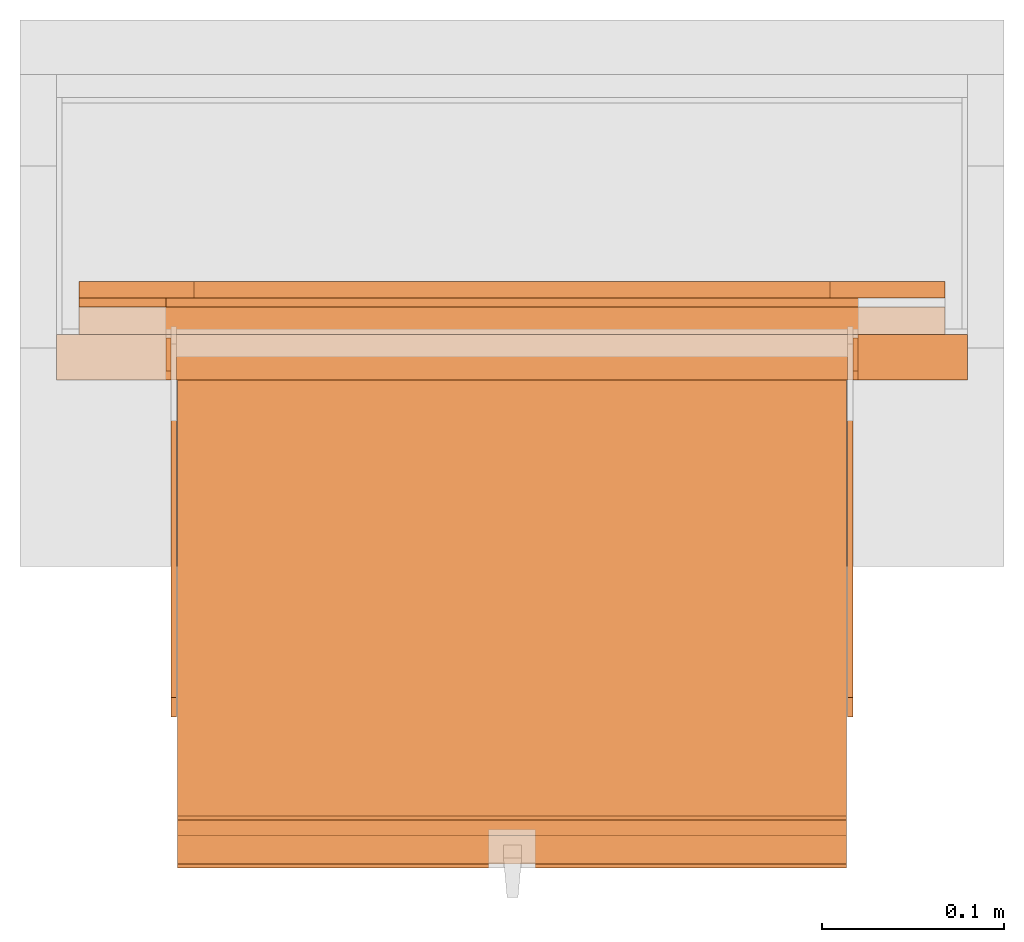
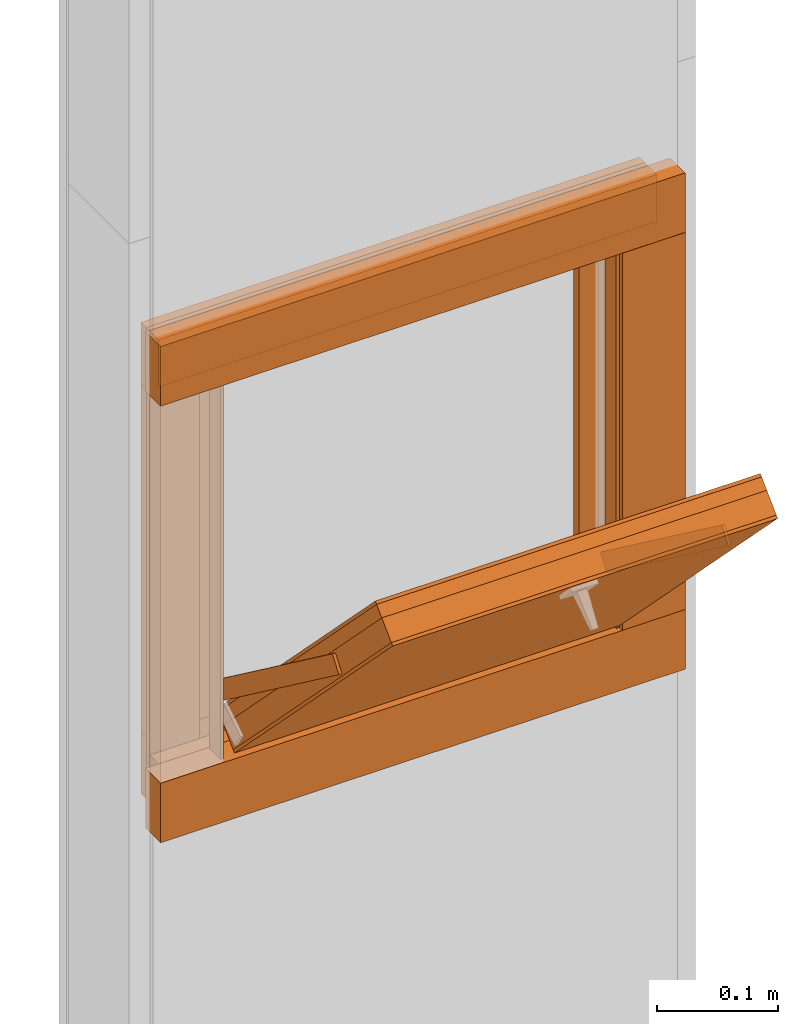
# One storey, part 2 of 4: 19 proxies.
"""IFC2X3 building model written with IfcOpenShell, lengths in metres."""

from ifc_helpers import new_model, entity, si_unit, converted_unit, derived_unit, money_unit, direction, frame, origin_with_axes, place, context, subcontext, project, spatial, polyline, outline, extrude, faceted_brep, source, transform, mapped, material, type_object, element, save


model = new_model("IFC2X3")

# Units and contexts
model_context = context("Model", 3, precision=1e-05, world=origin_with_axes(), true_north=direction((0.0, 1.0)))
plan_context = context("Plan", 3, precision=1e-05, world=origin_with_axes(), true_north=direction((0.0, 1.0)))
body_context = subcontext(model_context, "Body", "Model", "MODEL_VIEW")
ifc_project = project(units=[si_unit("LENGTHUNIT", "METRE"), si_unit("AREAUNIT", "SQUARE_METRE"), si_unit("VOLUMEUNIT", "CUBIC_METRE"), converted_unit("PLANEANGLEUNIT", "DEGREE", entity("IfcPlaneAngleMeasure", 0.0174532925199), si_unit("PLANEANGLEUNIT", "RADIAN"), dimensions=[0, 0, 0, 0, 0, 0, 0]), si_unit("SOLIDANGLEUNIT", "STERADIAN"), money_unit("CHF"), converted_unit("TIMEUNIT", "Year", entity("IfcTimeMeasure", 31556926.0), si_unit("TIMEUNIT", "SECOND"), dimensions=[0, 0, 1, 0, 0, 0, 0]), si_unit("MASSUNIT", "GRAM", prefix="KILO"), si_unit("THERMODYNAMICTEMPERATUREUNIT", "DEGREE_CELSIUS"), si_unit("LUMINOUSINTENSITYUNIT", "LUMEN"), si_unit("ENERGYUNIT", "JOULE", prefix="MEGA"), derived_unit("THERMALCONDUCTANCEUNIT", [(si_unit("POWERUNIT", "WATT"), 1), (si_unit("LENGTHUNIT", "METRE"), -1), (si_unit("THERMODYNAMICTEMPERATUREUNIT", "KELVIN"), -1)]), derived_unit("SPECIFICHEATCAPACITYUNIT", [(si_unit("ENERGYUNIT", "JOULE"), 1), (si_unit("MASSUNIT", "GRAM", prefix="KILO"), -1), (si_unit("THERMODYNAMICTEMPERATUREUNIT", "KELVIN"), -1)]), derived_unit("MASSDENSITYUNIT", [(si_unit("MASSUNIT", "GRAM", prefix="KILO"), 1), (si_unit("VOLUMEUNIT", "CUBIC_METRE"), -1)])], contexts=[model_context, plan_context])

# Site, building, storey
site_placement = place(None, origin_with_axes())
site = spatial("IfcSite", under=ifc_project, at=site_placement, CompositionType="ELEMENT")
building_placement = place(site_placement, origin_with_axes())
building = spatial("IfcBuilding", under=site, at=building_placement, CompositionType="ELEMENT")
storey_placement = place(building_placement, origin_with_axes())
storey = spatial("IfcBuildingStorey", under=building, at=storey_placement, Name="EG00", CompositionType="ELEMENT", Elevation=0.0)

# Proxies
ifc_material_1 = material(Name="Holz")
building_element_proxy_type_1 = type_object("IfcBuildingElementProxyType", Name="Holz 15", PredefinedType="NOTDEFINED")
for number, where, z_axis, x_axis, name in (
    (1, (9.60272436818, -8.21243070606, 0.5625), (0.0, 0.0, 1.0), (-1.0, 0.0, 0.0), "Wand-004"),
    (2, (9.60272436818, -8.21243070606, 0.99), (0.0, 0.0, 1.0), (-1.0, 0.0, 0.0), "Wand-004"),
):
    element("IfcBuildingElementProxy", number, at=place(storey_placement, frame(where, z_axis=z_axis, x_axis=x_axis)), inside=storey, type_object=building_element_proxy_type_1, material=ifc_material_1, Name=name, context=body_context, shape_type="SweptSolid", body=[
        extrude(outline(polyline([(0.0, 0.0), (0.475, 0.0), (0.475, 0.015), (0.0, 0.015), (0.0, 0.0)])), origin_with_axes(), (0.0, 0.0, 1.0), 0.0475),
    ])
building_element_proxy_type_2 = type_object("IfcBuildingElementProxyType", Name="Holz 5", PredefinedType="NOTDEFINED")
proxy_1_placement = place(storey_placement, frame((9.60272436818, -8.21243070606, 1.0), z_axis=(0.0, 0.0, 1.0), x_axis=(-1.0, 0.0, 0.0)))
element("IfcBuildingElementProxy", 3, at=proxy_1_placement, inside=storey, type_object=building_element_proxy_type_2, material=ifc_material_1, Name="Wand-004", context=body_context, shape_type="SweptSolid", body=[
    extrude(outline(polyline([(0.0, -0.005), (0.475, -0.005), (0.475, 0.0), (0.0, 0.0), (0.0, -0.005)])), origin_with_axes(), (0.0, 0.0, 1.0), 0.0375),
])
proxy_2_placement = place(storey_placement, frame((9.12772436818, -8.21243070606, 0.6), z_axis=(0.0, 0.0, 1.0), x_axis=(1.0, 0.0, 0.0)))
element("IfcBuildingElementProxy", 4, at=proxy_2_placement, inside=storey, type_object=building_element_proxy_type_2, material=ifc_material_1, Name="Wand-004", context=body_context, shape_type="SweptSolid", body=[
    extrude(outline(polyline([(0.0, 0.0), (0.0475, 0.0), (0.0475, 0.005), (0.0, 0.005), (0.0, 0.0)])), origin_with_axes(), (0.0, 0.0, 1.0), 0.4),
])
building_element_proxy_type_3 = type_object("IfcBuildingElementProxyType", Name="Holz 25", PredefinedType="NOTDEFINED")
for number, where, z_axis, x_axis, name in (
    (5, (9.61522436818, -8.22743070606, 0.55), (0.0, 0.0, 1.0), (-1.0, 0.0, 0.0), "Wand-004"),
    (6, (9.61522436818, -8.22743070606, 0.99), (0.0, 0.0, 1.0), (-1.0, 0.0, 0.0), "Wand-004"),
):
    element("IfcBuildingElementProxy", number, at=place(storey_placement, frame(where, z_axis=z_axis, x_axis=x_axis)), inside=storey, type_object=building_element_proxy_type_3, material=ifc_material_1, Name=name, context=body_context, shape_type="SweptSolid", body=[
        extrude(outline(polyline([(0.0, 0.0), (0.5, 0.0), (0.5, 0.025), (0.0, 0.025), (0.0, 0.0)])), origin_with_axes(), (0.0, 0.0, 1.0), 0.06),
    ])
proxy_3_placement = place(storey_placement, frame((9.55522436818, -8.25243070606, 0.61), z_axis=(0.0, 0.0, 1.0), x_axis=(1.0, 0.0, 0.0)))
element("IfcBuildingElementProxy", 7, at=proxy_3_placement, inside=storey, type_object=building_element_proxy_type_3, material=ifc_material_1, Name="Wand-004", context=body_context, shape_type="SweptSolid", body=[
    extrude(outline(polyline([(0.0, 0.0), (0.06, 0.0), (0.06, 0.025), (0.0, 0.025), (0.0, 0.0)])), origin_with_axes(), (0.0, 0.0, 1.0), 0.38),
])
ifc_material_2 = material(Name="Metall, Aluminium")
building_element_proxy_type_4 = type_object("IfcBuildingElementProxyType", Name="Metall, Aluminium 3", PredefinedType="NOTDEFINED")
proxy_4_placement = place(storey_placement, frame((9.17522436818, -8.22943070606, 0.61), z_axis=(0.0, 0.0, 1.0), x_axis=(0.0, -1.0, 0.0)))
element("IfcBuildingElementProxy", 8, at=proxy_4_placement, inside=storey, type_object=building_element_proxy_type_4, material=ifc_material_2, Name="Wand-006", context=body_context, shape_type="SweptSolid", body=[
    extrude(outline(polyline([(0.0, 0.0), (0.018, 0.0), (0.018, 0.003), (0.0, 0.003), (0.0, 0.0)])), origin_with_axes(), (0.0, 0.0, 1.0), 0.393521144674),
])
proxy_5_placement = place(storey_placement, frame((9.55522436818, -8.22943070606, 0.61), z_axis=(0.0, 0.0, 1.0), x_axis=(0.0, -1.0, 0.0)))
element("IfcBuildingElementProxy", 9, at=proxy_5_placement, inside=storey, type_object=building_element_proxy_type_4, material=ifc_material_2, Name="Wand-006", context=body_context, shape_type="SweptSolid", body=[
    extrude(outline(polyline([(0.0, -0.003), (0.018, -0.003), (0.018, 0.0), (0.0, 0.0), (0.0, -0.003)])), origin_with_axes(), (0.0, 0.0, 1.0), 0.393521144674),
])
building_element_proxy_type_5 = type_object("IfcBuildingElementProxyType", Name="Holz", PredefinedType="NOTDEFINED")
shared_shape_1 = source(origin_with_axes(), body_context, "Body", "Brep", [
    faceted_brep([(16.0840766769, -3.65867330347, 1.10947885533), (16.0840766769, -3.29167330347, 1.10947885533), (16.0840766769, -3.29167330347, 0.736478855326), (16.0840766769, -3.65867330347, 0.736478855326), (16.1060766769, -3.65867330347, 1.10947885533), (16.1060766769, -3.29167330347, 1.10947885533), (16.1060766769, -3.29167330347, 0.736478855326), (16.1060766769, -3.65867330347, 0.736478855326)], [[[0, 1, 2, 3]], [[1, 0, 4, 5]], [[2, 1, 5, 6]], [[3, 2, 6, 7]], [[0, 3, 7, 4]], [[4, 7, 6, 5]]]),
])
proxy_6_placement = place(storey_placement, frame((12.8403976717, 3.75690888182, 11.375802015), z_axis=(0.0, -0.700249431637, 0.713898265506), x_axis=(0.0, -0.713898265506, -0.700249431637)))
element("IfcBuildingElementProxy", 10, at=proxy_6_placement, inside=storey, type_object=building_element_proxy_type_5, material=ifc_material_1, Name="Wand-004", context=body_context, shape_type="MappedRepresentation", body=[
    mapped(shared_shape_1, transform((0.0, 0.0, 0.0))),
])
ifc_material_3 = material(Name="Gipsplatte horizontal")
building_element_proxy_type_6 = type_object("IfcBuildingElementProxyType", Name="Gipsplatte horizontal", PredefinedType="NOTDEFINED")
shared_shape_2 = source(origin_with_axes(), body_context, "Body", "Brep", [
    faceted_brep([(16.0720766769, -3.65867330347, 1.10947885533), (16.0720766769, -3.29167330347, 1.10947885533), (16.0720766769, -3.29167330347, 0.736478855326), (16.0720766769, -3.65867330347, 0.736478855326), (16.0840766769, -3.65867330347, 1.10947885533), (16.0840766769, -3.29167330347, 1.10947885533), (16.0840766769, -3.29167330347, 0.736478855326), (16.0840766769, -3.65867330347, 0.736478855326)], [[[0, 1, 2, 3]], [[1, 0, 4, 5]], [[2, 1, 5, 6]], [[3, 2, 6, 7]], [[0, 3, 7, 4]], [[4, 7, 6, 5]]]),
])
proxy_7_placement = place(storey_placement, frame((12.8403976717, 3.75690888182, 11.375802015), z_axis=(0.0, -0.700249431637, 0.713898265506), x_axis=(0.0, -0.713898265506, -0.700249431637)))
element("IfcBuildingElementProxy", 11, at=proxy_7_placement, inside=storey, type_object=building_element_proxy_type_6, material=ifc_material_3, Name="Wand-004", context=body_context, shape_type="MappedRepresentation", body=[
    mapped(shared_shape_2, transform((0.0, 0.0, 0.0))),
])
building_element_proxy_type_7 = type_object("IfcBuildingElementProxyType", Name="Holz 9", PredefinedType="NOTDEFINED")
for number, where, z_axis, x_axis, name in (
    (12, (9.60272436818, -8.20743070606, 0.5625), (0.0, 0.0, 1.0), (-1.0, 0.0, 0.0), "Wand-004"),
    (13, (9.60272436818, -8.20743070606, 0.975), (0.0, 0.0, 1.0), (-1.0, 0.0, 0.0), "Wand-004"),
):
    element("IfcBuildingElementProxy", number, at=place(storey_placement, frame(where, z_axis=z_axis, x_axis=x_axis)), inside=storey, type_object=building_element_proxy_type_7, material=ifc_material_1, Name=name, context=body_context, shape_type="SweptSolid", body=[
        extrude(outline(polyline([(0.0, -0.009), (0.475, -0.009), (0.475, 0.0), (0.0, 0.0), (0.0, -0.009)])), origin_with_axes(), (0.0, 0.0, 1.0), 0.0625),
    ])
for number, where, z_axis, x_axis, name in (
    (14, (9.53972436818, -8.20743070606, 0.625), (0.0, 0.0, 1.0), (1.0, 0.0, 0.0), "Wand-004"),
    (15, (9.12772436818, -8.20743070606, 0.625), (0.0, 0.0, 1.0), (1.0, 0.0, 0.0), "Wand-004"),
):
    element("IfcBuildingElementProxy", number, at=place(storey_placement, frame(where, z_axis=z_axis, x_axis=x_axis)), inside=storey, type_object=building_element_proxy_type_7, material=ifc_material_1, Name=name, context=body_context, shape_type="SweptSolid", body=[
        extrude(outline(polyline([(0.0, 0.0), (0.063, 0.0), (0.063, 0.009), (0.0, 0.009), (0.0, 0.0)])), origin_with_axes(), (0.0, 0.0, 1.0), 0.35),
    ])
building_element_proxy_type_8 = type_object("IfcBuildingElementProxyType", Name="Metall, Aluminium", PredefinedType="NOTDEFINED")
shared_shape_3 = source(origin_with_axes(), body_context, "Body", "Brep", [
    faceted_brep([(16.1060766769, -3.29167330347, 0.736478855326), (16.1060766769, -3.65867330347, 0.736478855326), (16.1060766769, -3.65867330347, 1.10947885533), (16.1060766769, -3.29167330347, 1.10947885533), (16.1091136769, -3.29167330347, 0.736478855326), (16.1091136769, -3.65867330347, 0.736478855326), (16.1091136769, -3.65867330347, 1.10947885533), (16.1091136769, -3.29167330347, 1.10947885533)], [[[0, 1, 2, 3]], [[1, 0, 4, 5]], [[2, 1, 5, 6]], [[3, 2, 6, 7]], [[0, 3, 7, 4]], [[5, 4, 7, 6]]]),
])
proxy_8_placement = place(storey_placement, frame((12.8403976717, 3.75690888182, 11.375802015), z_axis=(0.0, -0.700249431637, 0.713898265506), x_axis=(0.0, -0.713898265506, -0.700249431637)))
element("IfcBuildingElementProxy", 16, at=proxy_8_placement, inside=storey, type_object=building_element_proxy_type_8, material=ifc_material_2, Name="Wand-004", context=body_context, shape_type="MappedRepresentation", body=[
    mapped(shared_shape_3, transform((0.0, 0.0, 0.0))),
])
shared_shape_4 = source(origin_with_axes(), body_context, "Body", "Brep", [
    faceted_brep([(16.0690396769, -3.29167330347, 0.736478855326), (16.0690396769, -3.65867330347, 0.736478855326), (16.0690396769, -3.65867330347, 1.10947885533), (16.0690396769, -3.29167330347, 1.10947885533), (16.0720766769, -3.29167330347, 0.736478855326), (16.0720766769, -3.65867330347, 0.736478855326), (16.0720766769, -3.65867330347, 1.10947885533), (16.0720766769, -3.29167330347, 1.10947885533)], [[[0, 1, 2, 3]], [[1, 0, 4, 5]], [[2, 1, 5, 6]], [[3, 2, 6, 7]], [[0, 3, 7, 4]], [[5, 4, 7, 6]]]),
])
proxy_9_placement = place(storey_placement, frame((12.8403976717, 3.75690888182, 11.375802015), z_axis=(0.0, -0.700249431637, 0.713898265506), x_axis=(0.0, -0.713898265506, -0.700249431637)))
element("IfcBuildingElementProxy", 17, at=proxy_9_placement, inside=storey, type_object=building_element_proxy_type_8, material=ifc_material_2, Name="Wand-004", context=body_context, shape_type="MappedRepresentation", body=[
    mapped(shared_shape_4, transform((0.0, 0.0, 0.0))),
])
shared_shape_5 = source(origin_with_axes(), body_context, "Body", "Brep", [
    faceted_brep([(16.1152851057, -3.58730556817, 0.89), (16.1152851057, -3.59030556817, 0.89), (16.1152851057, -3.59030556817, 1.14), (16.1152851057, -3.58730556817, 1.14), (16.1332851057, -3.59030556817, 0.89), (16.1332851057, -3.58730556817, 0.89), (16.1332851057, -3.59030556817, 1.14), (16.1332851057, -3.58730556817, 1.14)], [[[0, 1, 2, 3]], [[4, 1, 0, 5]], [[1, 4, 6, 2]], [[2, 6, 7, 3]], [[0, 3, 7, 5]], [[4, 5, 7, 6]]]),
])
for number, where, z_axis, x_axis, name in (
    (18, (13.1395299364, 2.09768488745, 13.081222354), (0.0, -0.80277012101, 0.596288632135), (0.0, -0.596288632135, -0.80277012101), "Wand-004"),
    (19, (12.7685299364, 2.09768488745, 13.081222354), (0.0, -0.80277012101, 0.596288632135), (0.0, -0.596288632135, -0.80277012101), "Wand-004"),
):
    element("IfcBuildingElementProxy", number, at=place(storey_placement, frame(where, z_axis=z_axis, x_axis=x_axis)), inside=storey, type_object=building_element_proxy_type_8, material=ifc_material_2, Name=name, context=body_context, shape_type="MappedRepresentation", body=[
        mapped(shared_shape_5, transform((0.0, 0.0, 0.0))),
    ])

save(model, "model.ifc")
